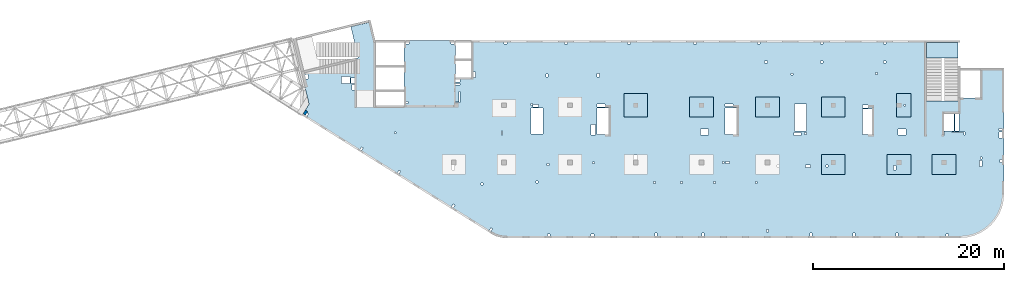
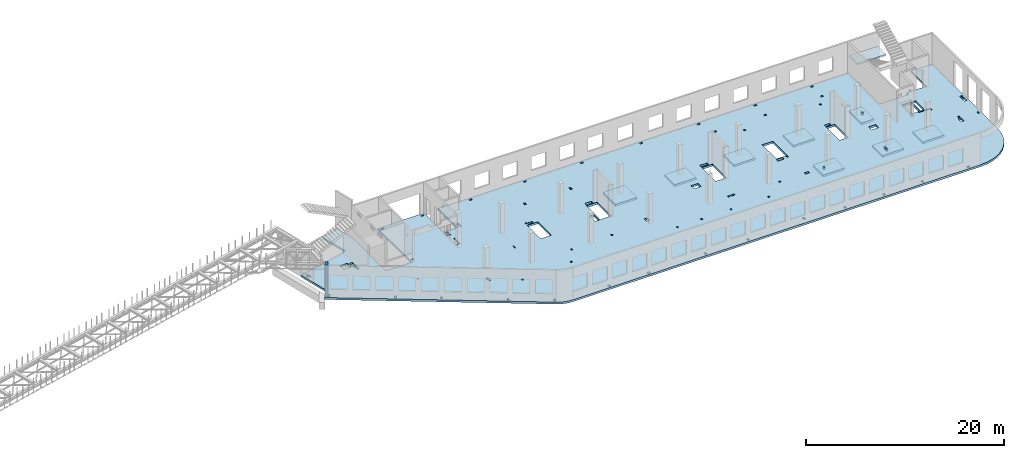
# One storey, part 14 of 67: 10 slabs, 1 wall.
"""IFC4 building model written with IfcOpenShell, lengths in millimetres."""

from ifc_helpers import new_model, entity, si_unit, converted_unit, derived_unit, direction, frame, origin, place, context, subcontext, project, spatial, indexed_curve, outline, extrude, material, type_object, element, save


model = new_model("IFC4")

# Units and contexts
model_context = context("Model", 3, precision=0.01, world=origin(), true_north=direction((6.12303176911189e-17, 1.0)))
plan_context = context("Plan", 3, precision=0.01, world=origin(), true_north=direction((6.12303176911189e-17, 1.0)))
body_context = subcontext(model_context, "Body", "Model", "MODEL_VIEW")
ifc_project = project(units=[si_unit("LENGTHUNIT", "METRE", prefix="MILLI"), si_unit("AREAUNIT", "SQUARE_METRE"), si_unit("VOLUMEUNIT", "CUBIC_METRE"), converted_unit("PLANEANGLEUNIT", "DEGREE", entity("IfcRatioMeasure", 0.0174532925199433), si_unit("PLANEANGLEUNIT", "RADIAN"), dimensions=[0, 0, 0, 0, 0, 0, 0]), si_unit("MASSUNIT", "GRAM", prefix="KILO"), derived_unit("MASSDENSITYUNIT", [(si_unit("MASSUNIT", "GRAM", prefix="KILO"), 1), (si_unit("LENGTHUNIT", "METRE"), -3)]), derived_unit("MOMENTOFINERTIAUNIT", [(si_unit("LENGTHUNIT", "METRE"), 4)]), si_unit("TIMEUNIT", "SECOND"), si_unit("FREQUENCYUNIT", "HERTZ"), si_unit("THERMODYNAMICTEMPERATUREUNIT", "DEGREE_CELSIUS"), derived_unit("THERMALTRANSMITTANCEUNIT", [(si_unit("MASSUNIT", "GRAM", prefix="KILO"), 1), (si_unit("THERMODYNAMICTEMPERATUREUNIT", "KELVIN"), -1), (si_unit("TIMEUNIT", "SECOND"), -3)]), derived_unit("VOLUMETRICFLOWRATEUNIT", [(si_unit("LENGTHUNIT", "METRE"), 3), (si_unit("TIMEUNIT", "SECOND"), -1)]), derived_unit("MASSFLOWRATEUNIT", [(si_unit("MASSUNIT", "GRAM", prefix="KILO"), 1), (si_unit("TIMEUNIT", "SECOND"), -1)]), derived_unit("ROTATIONALFREQUENCYUNIT", [(si_unit("TIMEUNIT", "SECOND"), -1)]), si_unit("ELECTRICCURRENTUNIT", "AMPERE"), si_unit("ELECTRICVOLTAGEUNIT", "VOLT"), si_unit("POWERUNIT", "WATT"), si_unit("FORCEUNIT", "NEWTON", prefix="KILO"), si_unit("ILLUMINANCEUNIT", "LUX"), si_unit("LUMINOUSFLUXUNIT", "LUMEN"), si_unit("LUMINOUSINTENSITYUNIT", "CANDELA"), derived_unit("USERDEFINED", [(si_unit("MASSUNIT", "GRAM", prefix="KILO"), -1), (si_unit("LENGTHUNIT", "METRE"), -2), (si_unit("TIMEUNIT", "SECOND"), 3), (si_unit("LUMINOUSFLUXUNIT", "LUMEN"), 1)]), derived_unit("LINEARVELOCITYUNIT", [(si_unit("LENGTHUNIT", "METRE"), 1), (si_unit("TIMEUNIT", "SECOND"), -1)]), si_unit("PRESSUREUNIT", "PASCAL"), derived_unit("USERDEFINED", [(si_unit("LENGTHUNIT", "METRE"), -2), (si_unit("MASSUNIT", "GRAM", prefix="KILO"), 1), (si_unit("TIMEUNIT", "SECOND"), -2)]), derived_unit("LINEARFORCEUNIT", [(si_unit("MASSUNIT", "GRAM", prefix="KILO"), 1), (si_unit("LENGTHUNIT", "METRE"), 1), (si_unit("TIMEUNIT", "SECOND"), -2), (si_unit("LENGTHUNIT", "METRE"), -1)]), derived_unit("PLANARFORCEUNIT", [(si_unit("MASSUNIT", "GRAM", prefix="KILO"), 1), (si_unit("LENGTHUNIT", "METRE"), 1), (si_unit("TIMEUNIT", "SECOND"), -2), (si_unit("LENGTHUNIT", "METRE"), -2)])], contexts=[model_context, plan_context])

# Site, building, storey
site_placement = place(None, origin())
site = spatial("IfcSite", under=ifc_project, at=site_placement, CompositionType="ELEMENT")
building_placement = place(site_placement, origin())
building = spatial("IfcBuilding", under=site, at=building_placement, CompositionType="ELEMENT")
storey_placement = place(building_placement, frame((0.0, 0.0, 19800.0)))
storey = spatial("IfcBuildingStorey", under=building, at=storey_placement, CompositionType="ELEMENT", Elevation=19800.0)

# Slabs
ifc_material = material()
slab_type_1 = type_object("IfcSlabType", PredefinedType="FLOOR", material=ifc_material)
slab_1_placement = place(storey_placement, origin())
element("IfcSlab", 1, at=slab_1_placement, inside=storey, type_object=slab_type_1, material=ifc_material, PredefinedType="FLOOR", context=body_context, shape_type="SweptSolid", body=[
    extrude(outline(indexed_curve([(-25035.3578436615, -19149.6834192696), (-1723.7807546778, -19149.6834192696), (-1545.14847241192, -19144.6936708545), (-1367.07327148811, -19129.7399866024), (-1190.11049593861, -19104.8690009648), (-1014.81202059395, -19070.1582764174), (-841.72453001009, -19025.7160615744), (-671.387813581896, -18971.6809536053), (-504.333082159904, -18908.2214660066), (-341.081311419952, -18835.5355030768), (-182.14161715224, -18753.8497427335), (-28.0096675365007, -18663.4189295977), (40258.2427502764, 6510.83324029911), (40838.4797487777, 6940.19687309205), (41344.4069782413, 7455.0433348891), (41763.5656731431, 8042.69563789314), (42085.6347553066, 8688.68383209804), (42302.6838150429, 9377.10154425057), (42409.3683841568, 10090.9976455501), (42403.0615344909, 10812.7936446974), (42283.9185616152, 11524.7165286898), (42054.8731609348, 12209.2363933869), (41721.5651903726, 12849.4980879286), (34742.4070907115, 24018.2161483196), (32622.301916857, 22693.3954199037), (34265.0803766703, 20064.4637935763), (32314.5829786219, 18845.6283246935), (32494.7586566307, 18557.2939267212), (29662.2972177258, 16787.3328545174), (26286.6526837235, 22189.3629466861), (-14169.2074788393, -3090.87446333766), (-12102.4862527243, -6398.23995847165), (-13480.5550665628, -7259.37371366059), (-15547.2762926778, -3952.0082185266), (-20126.7049663564, -6813.62192807755), (-16496.694769283, -12622.7123467952), (-19040.8218102156, -14212.4977409902), (-22670.832007289, -8403.40732227252), (-22712.6876077937, -8429.56223563854), (-24284.2776411098, -6895.90698258245), (-24423.9609210558, -7039.04531184302), (-24280.8225917953, -7178.7285917891), (-25628.7662432749, -8560.01346915358), (-23238.3778486726, -10892.7277685588), (-27547.6230145679, -15308.5133809195), (-25035.3846887576, -17760.1502337417), (-25035.3578436615, -19149.6834192696)], self_intersect=False), holes=[indexed_curve([(-22133.29936942, -13415.1223301469), (-22442.8348260668, -13608.5462197739), (-22760.7919049058, -13099.7208115874), (-22451.256448259, -12906.2969219603), (-22133.29936942, -13415.1223301469)], self_intersect=False), indexed_curve([(-21775.5976557261, -13987.5509143567), (-21987.6082424705, -14120.0330305396), (-22284.3681827202, -13645.1293162322), (-22072.3575959758, -13512.6472000493), (-21775.5976557261, -13987.5509143567)], self_intersect=False), indexed_curve([(-11722.1849951182, -9261.85584637686), (-12086.8432043185, -9489.72508621147), (-12129.2374814971, -9421.88169845327), (-11832.4226600549, -9236.40673579719), (-12415.3439712598, -8303.56015412191), (-12347.5005835016, -8261.16587694338), (-11722.1849951182, -9261.85584637686)], self_intersect=False), indexed_curve([(-13242.0872574336, -7640.99276980047), (-13374.5693736165, -7428.98218305609), (-13009.9111644161, -7201.11294322148), (-12877.4290482332, -7413.12352996586), (-13242.0872574336, -7640.99276980047)], self_intersect=False), indexed_curve([(-5628.70693935832, -1916.57657305384), (-5459.09846996282, -1810.5908801075), (-5289.52136124868, -2081.96443114031), (-5459.12983064419, -2187.95012408664), (-5628.70693935832, -1916.57657305384)], self_intersect=False), indexed_curve([(34805.8880217444, 16198.6065676781), (34986.0636997531, 15910.2721697058), (34918.2203119949, 15867.8778925273), (34780.4389111647, 16088.3689027414), (33677.9838600939, 15399.4618985902), (33635.5895829154, 15467.3052863485), (34805.8880217444, 16198.6065676781)], self_intersect=False), indexed_curve([(37927.9797280557, 14617.8898262316), (38251.236091542, 14100.5839945753), (37988.3429639789, 13936.3061705085), (37665.0866004926, 14453.6120021647), (37927.9797280557, 14617.8898262316)], self_intersect=False), indexed_curve([(-1135.1376532047, 950.344261314779), (-940.08791339986, 1072.22780820307), (-749.313666096461, 766.932563291155), (-944.363405901299, 645.04901640287), (-1135.1376532047, 950.344261314779)], self_intersect=False), indexed_curve([(16089.6652817492, 11749.2314200073), (16259.2737511447, 11855.2171129536), (16365.259444091, 11685.6086435581), (16195.6509746955, 11579.6229506118), (16089.6652817492, 11749.2314200073)], self_intersect=False), indexed_curve([(23569.4069610802, 16517.5397477249), (23739.0154304757, 16623.5254406713), (23845.001123422, 16453.9169712758), (23675.3926540265, 16347.9312783294), (23569.4069610802, 16517.5397477249)], self_intersect=False), indexed_curve([(-4628.33119641944, -5064.85428712623), (-4495.84908023653, -5276.86487387061), (-4970.75279454395, -5573.62481412034), (-5103.23491072686, -5361.61422737596), (-4628.33119641944, -5064.85428712623)], self_intersect=False), indexed_curve([(-4030.49662256684, -5115.78386896694), (-2594.39048314403, -7413.97862927603), (-3662.92384033572, -8081.68849483792), (-5099.02997975852, -5783.49373452883), (-4030.49662256684, -5115.78386896694)], self_intersect=False), indexed_curve([(1253.91022629488, -1306.59011826816), (1423.48733500901, -1577.96366930096), (728.092610487371, -2012.50501038096), (558.515501773239, -1741.13145934816), (1253.91022629488, -1306.59011826816)], self_intersect=False), indexed_curve([(1843.25645725139, -1457.15866891798), (3313.80794688175, -3810.4761817806), (2245.27458969007, -4478.18604734249), (774.723100059713, -2124.86853447986), (1843.25645725139, -1457.15866891798)], self_intersect=False), indexed_curve([(1740.68547315327, -4840.66338935521), (1163.06344659577, -3916.29723114972), (1553.16292620543, -3672.53013737315), (2130.78495276294, -4596.89629557865), (1740.68547315327, -4840.66338935521)], self_intersect=False), indexed_curve([(11463.4910605066, 1234.9663319602), (11145.5339816676, 1743.79174014671), (11849.4091296589, 2183.63236587399), (12167.3662084979, 1674.80695768748), (11463.4910605066, 1234.9663319602)], self_intersect=False), indexed_curve([(14896.1975903923, 72.3933752474018), (15065.8060597878, 178.379068193729), (15171.7917527341, 8.77059879822273), (15002.1832833386, -97.2150941481066), (14896.1975903923, 72.3933752474018)], self_intersect=False), indexed_curve([(12634.6385227333, 5805.04987843064), (12788.3177775055, 5559.11759780716), (12059.0013591048, 5103.37911813794), (11905.3221043326, 5349.31139876142), (12634.6385227333, 5805.04987843064)], self_intersect=False), indexed_curve([(13207.0239067502, 5643.88275848624), (14677.5753963806, 3290.56524562361), (13609.0420391889, 2622.85538006173), (12138.4905495585, 4976.17289292435), (13207.0239067502, 5643.88275848624)], self_intersect=False), indexed_curve([(19150.2533898443, 9870.66027583487), (20665.8487989769, 7445.25916347915), (19597.3154417852, 6777.54929791726), (18081.7200326527, 9202.95041027297), (19150.2533898443, 9870.66027583487)], self_intersect=False), indexed_curve([(20240.2252958214, 7031.8953605626), (20399.2038352409, 6777.48265646934), (19780.1329219473, 6390.63487721523), (19621.1543825278, 6645.04758130849), (20240.2252958214, 7031.8953605626)], self_intersect=False), indexed_curve([(25270.9461080048, 13058.6252458208), (26685.8551088383, 10794.3521793908), (25837.8127618608, 10264.4237146591), (24422.9037610273, 12528.6967810891), (25270.9461080048, 13058.6252458208)], self_intersect=False), indexed_curve([(28111.3878345621, 15193.224926799), (27941.7793651666, 15087.2392338527), (27835.7936722203, 15256.8477032482), (28005.4021416158, 15362.8333961945), (28111.3878345621, 15193.224926799)], self_intersect=False), indexed_curve([(29412.3642136373, 13158.4498458438), (29730.3212924763, 12649.6244376573), (29115.4924335878, 12265.4274521827), (29017.9675636854, 12204.4856787385), (28700.0104848464, 12713.3110869251), (28797.5335120786, 12774.2517089133), (29412.3642136373, 13158.4498458438)], self_intersect=False), indexed_curve([(23022.5065390695, 4466.46925882629), (22598.4853655807, 4201.50502646046), (22466.0032493978, 4413.51561320483), (22890.0244228865, 4678.47984557067), (23022.5065390695, 4466.46925882629)], self_intersect=False), indexed_curve([(-10781.317628673, -1445.50910142009), (-11035.7303327662, -1604.48764083959), (-11141.7160257126, -1434.87917144409), (-10887.3033216193, -1275.90063202459), (-10781.317628673, -1445.50910142009)], self_intersect=False), indexed_curve([(-5396.2487253657, 1919.53664962593), (-5650.66142945896, 1760.55811020644), (-5756.64712240529, 1930.16657960194), (-5502.23441831203, 2089.14511902144), (-5396.2487253657, 1919.53664962593)], self_intersect=False), indexed_curve([(-19490.7125321322, -6887.87443421422), (-19745.1252362254, -7046.85297363371), (-19851.1109291718, -6877.24450423821), (-19596.6982250785, -6718.26596481871), (-19490.7125321322, -6887.87443421422)], self_intersect=False), indexed_curve([(200.830764685962, 5417.06451685487), (-53.5819394072999, 5258.08597743537), (-159.567632353634, 5427.69444683087), (94.8450717396271, 5586.67298625037), (200.830764685962, 5417.06451685487)], self_intersect=False), indexed_curve([(6052.32295883088, 9073.57092350331), (5797.91025473762, 8914.59238408381), (5691.92456179129, 9084.20085347932), (5946.33726588455, 9243.17939289881), (6052.32295883088, 9073.57092350331)], self_intersect=False), indexed_curve([(11734.2066835803, 12624.0916372054), (11479.793979487, 12465.1130977859), (11373.8082865407, 12634.7215671814), (11628.220990634, 12793.7001066009), (11734.2066835803, 12624.0916372054)], self_intersect=False), indexed_curve([(17331.286173632, 16121.6195044343), (17076.8734695387, 15962.6409650148), (16970.8877765924, 16132.2494344104), (17225.3004806856, 16291.2279738298), (17331.286173632, 16121.6195044343)], self_intersect=False), indexed_curve([(22928.3656636836, 19619.1473716633), (22673.9529595903, 19460.1688322438), (22567.967266644, 19629.7773016393), (22822.3799707373, 19788.7558410588), (22928.3656636836, 19619.1473716633)], self_intersect=False), indexed_curve([(23977.6240238523, 17940.0235246478), (23723.211319759, 17781.0449852283), (23617.2256268127, 17950.6534546238), (23871.6383309059, 18109.6319940433), (23977.6240238523, 17940.0235246478)], self_intersect=False), indexed_curve([(18380.5445338006, 14442.4956574189), (18126.1318297074, 14283.5171179994), (18020.1461367611, 14453.1255873949), (18274.5588408543, 14612.1041268144), (18380.5445338006, 14442.4956574189)], self_intersect=False), indexed_curve([(13419.4968039821, 11342.4141387387), (13165.0840998889, 11183.4355993192), (13059.0984069425, 11353.0440687147), (13313.5111110358, 11512.0226081342), (13419.4968039821, 11342.4141387387)], self_intersect=False), indexed_curve([(-22943.636825664, -13042.9957293671), (-22551.4897617626, -13670.5470661305), (-23314.7278740424, -14147.482684389), (-23706.8749379438, -13519.9313476256), (-22943.636825664, -13042.9957293671)], self_intersect=False), indexed_curve([(-26693.9639157555, -15722.3725280137), (-27051.8095806284, -15373.1644826066), (-26842.2848799564, -15158.457213386), (-26484.4419576682, -15507.6680692153), (-26693.9639157555, -15722.3725280137)], self_intersect=False), indexed_curve([(-24735.3672304539, -18649.9890495262), (-24535.3672304924, -18649.9851256142), (-24535.3613446244, -18949.9851255565), (-24735.3613445859, -18949.9890494685), (-24735.3672304539, -18649.9890495262)], self_intersect=False), indexed_curve([(-17995.3672317511, -18649.8568136923), (-17795.3672317896, -18649.8528897804), (-17795.3613459216, -18949.8528897226), (-17995.3613458831, -18949.8568136346), (-17995.3672317511, -18649.8568136923)], self_intersect=False), indexed_curve([(-13365.3672326422, -18649.7659751299), (-13165.3672326807, -18649.7620512179), (-13165.3613468127, -18949.7620511602), (-13365.3613467742, -18949.7659750722), (-13365.3672326422, -18649.7659751299)], self_intersect=False), indexed_curve([(-6665.36723393173, -18649.6345240786), (-6465.36723397022, -18649.6306001666), (-6465.36134810225, -18949.6306001088), (-6665.36134806376, -18949.6345240208), (-6665.36723393173, -18649.6345240786)], self_intersect=False), indexed_curve([(-1995.36723483054, -18649.5429007335), (-1795.36723486903, -18649.5389768216), (-1795.36134900105, -18949.5389767638), (-1995.36134896257, -18949.5429006758), (-1995.36723483054, -18649.5429007335)], self_intersect=False), indexed_curve([(-15760.2274862019, -15405.2679960053), (-15680.7382164921, -15532.4743480519), (-15807.9445685388, -15611.9636177617), (-15887.4338382485, -15484.7572657151), (-15760.2274862019, -15405.2679960053)], self_intersect=False), indexed_curve([(-16289.959946675, -12198.7303741582), (-16459.5684160705, -12304.7160671045), (-16565.5541090168, -12135.107597709), (-16395.9456396213, -12029.1219047627), (-16289.959946675, -12198.7303741582)], self_intersect=False), indexed_curve([(-5197.32627309738, -15136.9063702166), (-5091.34058015106, -15306.5148396121), (-5260.94904954656, -15412.5005325584), (-5366.93474249289, -15242.8920631629), (-5197.32627309738, -15136.9063702166)], self_intersect=False), indexed_curve([(-6114.83658600321, -9743.560306838), (-6199.64082070096, -9796.55315331116), (-6411.61220659362, -9457.33621452015), (-6326.80797189587, -9404.34336804699), (-6114.83658600321, -9743.560306838)], self_intersect=False), indexed_curve([(3605.89099011392, -15920.9764032486), (3711.87668306025, -16090.5848726441), (3457.463978967, -16249.5634120636), (3351.47828602067, -16079.9549426681), (3605.89099011392, -15920.9764032486)], self_intersect=False), indexed_curve([(7489.92493927099, -13493.9040347776), (7595.91063221732, -13663.5125041731), (7341.49792812406, -13822.4910435926), (7235.51223517773, -13652.8825741971), (7489.92493927099, -13493.9040347776)], self_intersect=False), indexed_curve([(-394.20584995626, -11887.8820242313), (-288.220157009933, -12057.4904936268), (-457.828626405432, -12163.4761865732), (-563.814319351763, -11993.8677171777), (-394.20584995626, -11887.8820242313)], self_intersect=False), indexed_curve([(-431.124438654749, -9705.87331256026), (-325.138745708416, -9875.48178195576), (-494.747215103917, -9981.4674749021), (-600.73290805025, -9811.85900550659), (-431.124438654749, -9705.87331256026)], self_intersect=False), indexed_curve([(-5353.39564282971, -5376.43340797962), (-5200.74802037376, -5281.04628432792), (-5094.76232742743, -5450.65475372343), (-5247.40994988338, -5546.04187737513), (-5353.39564282971, -5376.43340797962)], self_intersect=False), indexed_curve([(3535.0797832171, -7032.88826389166), (3641.06547616344, -7202.49673328717), (3471.45700676793, -7308.4824262335), (3365.4713138216, -7138.873956838), (3535.0797832171, -7032.88826389166)], self_intersect=False), indexed_curve([(-13069.8605063958, -7916.60653256817), (-13149.3497761055, -7789.40018052154), (-12784.6915669052, -7561.53094068692), (-12705.2022971954, -7688.73729273355), (-13069.8605063958, -7916.60653256817)], self_intersect=False), indexed_curve([(12872.8835369238, -10012.2583411499), (13042.4920063193, -9906.27264820362), (13201.4705457388, -10160.6853522969), (13031.8620763433, -10266.6710452432), (12872.8835369238, -10012.2583411499)], self_intersect=False), indexed_curve([(17070.6931544625, -7389.11244072825), (17240.301623858, -7283.12674778192), (17399.2801632775, -7537.53945187517), (17229.671693882, -7643.5251448215), (17070.6931544625, -7389.11244072825)], self_intersect=False), indexed_curve([(10078.5817186322, -5408.45531014478), (10184.5674115785, -5578.06377954029), (10014.958942183, -5684.04947248662), (9908.97324923671, -5514.44100309111), (10078.5817186322, -5408.45531014478)], self_intersect=False), indexed_curve([(12461.5807136391, -3919.35632424882), (12567.5664065854, -4088.96479364433), (12397.9579371899, -4194.95048659066), (12291.9722442436, -4025.34201719516), (12461.5807136391, -3919.35632424882)], self_intersect=False), indexed_curve([(15378.8463872417, -2096.40240557192), (15484.8320801881, -2266.01087496742), (15315.2236107926, -2371.99656791375), (15209.2379178463, -2202.38809851824), (15378.8463872417, -2096.40240557192)], self_intersect=False), indexed_curve([(19101.7522904731, 229.983554600057), (19207.7379834194, 60.3750852045558), (19038.1295140239, -45.6106077417833), (18932.1438210776, 123.99786165372), (19101.7522904731, 229.983554600057)], self_intersect=False), indexed_curve([(22566.0467637286, -3483.47693429318), (22735.6552331241, -3377.49124134686), (22894.6337725436, -3631.90394544011), (22725.0253031481, -3737.88963838644), (22566.0467637286, -3483.47693429318)], self_intersect=False), indexed_curve([(15193.0124118344, 257.868337903477), (15549.190197565, 480.43829309077), (15655.1758905113, 310.829823695274), (15298.9981047808, 88.2598685079719), (15193.0124118344, 257.868337903477)], self_intersect=False), indexed_curve([(20835.425907691, 7173.88561244634), (20665.8174382955, 7067.89991950001), (20559.8317453492, 7237.50838889551), (20729.4402147447, 7343.49408184184), (20835.425907691, 7173.88561244634)], self_intersect=False), indexed_curve([(26645.0912518388, -1406.22007390789), (26814.6997212343, -1300.23438096156), (26973.6782606538, -1554.64708505483), (26804.0697912583, -1660.63277800115), (26645.0912518388, -1406.22007390789)], self_intersect=False), indexed_curve([(30469.7622367074, 983.757302031897), (30639.3707061029, 1089.74299497822), (30798.3492455224, 835.330290884961), (30628.7407761269, 729.344597938634), (30469.7622367074, 983.757302031897)], self_intersect=False), indexed_curve([(34294.4332215761, 3373.73467797166), (34464.0416909716, 3479.72037091801), (34623.0202303911, 3225.30766682474), (34453.4117609956, 3119.3219738784), (34294.4332215761, 3373.73467797166)], self_intersect=False), indexed_curve([(24359.3123452595, 12630.4618627264), (24208.282732811, 12872.153931615), (24717.1081409975, 13190.111010454), (24868.137753446, 12948.4189415654), (24359.3123452595, 12630.4618627264)], self_intersect=False), indexed_curve([(38774.2071192719, 6055.15702917322), (39028.6198233651, 6214.13556859271), (39134.6055163114, 6044.52709919721), (38880.1928122182, 5885.54855977772), (38774.2071192719, 6055.15702917322)], self_intersect=False), indexed_curve([(37832.592604404, 14770.5374486875), (37662.9841350085, 14664.5517557412), (37556.9984420621, 14834.1602251367), (37726.6069114576, 14940.145918083), (37832.592604404, 14770.5374486875)], self_intersect=False), indexed_curve([(39633.5850115564, 15436.066880475), (39474.6064721369, 15690.4795845682), (39644.2142479431, 15796.4648441014), (39803.1927873626, 15542.0521400081), (39633.5850115564, 15436.066880475)], self_intersect=False), indexed_curve([(37667.5340334719, 18393.6239323588), (37921.9474311545, 18552.6029051915), (38027.9331241009, 18382.994435796), (37773.5197264183, 18224.0154629633), (37667.5340334719, 18393.6239323588)], self_intersect=False), indexed_curve([(37860.957923099, 18084.088475712), (38115.3713207816, 18243.0674485447), (38433.3283996206, 17734.2420403582), (38178.915001938, 17575.2630675255), (37860.957923099, 18084.088475712)], self_intersect=False), indexed_curve([(33008.038246152, 15075.158222447), (33188.2139241608, 14786.8238244747), (33120.3705364026, 14744.4295472962), (32940.1948583938, 15032.7639452685), (33008.038246152, 15075.158222447)], self_intersect=False), indexed_curve([(32802.046604642, 17216.3710665211), (33758.5674834826, 15685.6546302267), (32876.603442626, 15134.5290269058), (31920.0825637853, 16665.2454632002), (32802.046604642, 17216.3710665211)], self_intersect=False), indexed_curve([(33234.5482016005, 17486.6345835343), (34191.0690804411, 15955.9181472398), (33860.3325651199, 15749.2460459945), (32903.8116862793, 17279.9624822889), (33183.6656607819, 17454.8388756504), (33234.5482016005, 17486.6345835343)], self_intersect=False), indexed_curve([(-8724.99463551253, -15077.252738595), (-8428.2346952628, -15552.1564529024), (-8640.24528200717, -15684.6385690853), (-8937.0052222569, -15209.7348547779), (-8724.99463551253, -15077.252738595)], self_intersect=False), indexed_curve([(7203.41403081956, -4487.07820658831), (6923.56005631698, -4661.95459994976), (6642.6979700092, -4212.49215605167), (6922.55194451179, -4037.61576269022), (7203.41403081956, -4487.07820658831)], self_intersect=False), indexed_curve([(20197.470370807, 2760.1074425607), (20027.8619014115, 2654.12174961437), (19921.8762084652, 2823.73021900988), (20091.4846778607, 2929.7159119562), (20197.470370807, 2760.1074425607)], self_intersect=False), indexed_curve([(24577.608729869, 5497.18854393024), (24408.0002604735, 5391.20285098393), (24302.0145675272, 5560.81132037942), (24471.6230369227, 5666.79701332575), (24577.608729869, 5497.18854393024)], self_intersect=False), indexed_curve([(30785.2437920549, 8951.73517525887), (30573.2332053105, 8819.25305907597), (30308.2689729447, 9243.27423256473), (30520.2795596891, 9375.75634874763), (30785.2437920549, 8951.73517525887)], self_intersect=False), indexed_curve([(-15504.9135013378, -4397.21064997542), (-15759.326205431, -4556.18918939492), (-15865.3118983774, -4386.58071999942), (-15610.8991942841, -4227.60218057992), (-15504.9135013378, -4397.21064997542)], self_intersect=False), indexed_curve([(-12229.6379372401, -5817.35020929626), (-12017.6273504957, -5684.86809311334), (-11720.8674102459, -6159.77180742076), (-11932.8779969903, -6292.25392360367), (-12229.6379372401, -5817.35020929626)], self_intersect=False)]), frame((31379.0305927559, 15612.5256979213, -400.0), z_axis=(0.0, 0.0, 1.0), x_axis=(0.848042346977523, -0.52992846473166, 0.0)), (0.0, 0.0, 1.0), 249.999999999999),
])
slab_type_2 = type_object("IfcSlabType", PredefinedType="FLOOR", material=ifc_material)
slab_2_placement = place(storey_placement, origin())
element("IfcSlab", 2, at=slab_2_placement, inside=storey, type_object=slab_type_2, material=ifc_material, PredefinedType="FLOOR", context=body_context, shape_type="SweptSolid", body=[
    extrude(outline(indexed_curve([(-1249.99990844727, -1049.99999999999), (1249.99990844727, -1049.99999999999), (1249.99990844727, 1049.99999999999), (-1249.99990844727, 1049.99999999999), (-1249.99990844727, -1049.99999999999)], self_intersect=False), holes=[indexed_curve([(534.999908447283, 49.999314856667), (534.999908447283, 249.999314856666), (734.999908447263, 249.999314856666), (734.999908447263, 49.999314856667), (534.999908447283, 49.999314856667)], self_intersect=False)]), frame((55670.0001770019, 7499.99922635556, -650.0), z_axis=(0.0, 0.0, 1.0), x_axis=(-1.0, 0.0, 0.0)), (0.0, 0.0, 1.0), 249.999999999999),
])
slab_type_3 = type_object("IfcSlabType", PredefinedType="FLOOR", material=ifc_material)
slab_3_placement = place(storey_placement, origin())
element("IfcSlab", 3, at=slab_3_placement, inside=storey, type_object=slab_type_3, material=ifc_material, PredefinedType="FLOOR", context=body_context, shape_type="SweptSolid", body=[
    extrude(outline(indexed_curve([(-1249.99999999999, -1050.0), (1250.00000000001, -1050.0), (1250.00000000001, 1050.0), (-1249.99999999999, 1050.0), (-1249.99999999999, -1050.0)], self_intersect=False), holes=[indexed_curve([(340.000000000009, 110.000000000013), (340.000000000009, 610.000000000013), (590.000000000004, 610.000000000013), (590.000000000004, 110.000000000013), (340.000000000009, 110.000000000013)], self_intersect=False)]), frame((62570.0002685547, 7499.99922635553, -650.0), z_axis=(0.0, 0.0, 1.0), x_axis=(-1.0, 0.0, 0.0)), (0.0, 0.0, 1.0), 249.999999999999),
])
slab_type_4 = type_object("IfcSlabType", PredefinedType="FLOOR", material=ifc_material)
slab_4_placement = place(storey_placement, origin())
element("IfcSlab", 4, at=slab_4_placement, inside=storey, type_object=slab_type_4, material=ifc_material, PredefinedType="FLOOR", context=body_context, shape_type="SweptSolid", body=[
    extrude(outline(indexed_curve([(-1050.0, -1249.99999999999), (1050.0, -1249.99999999999), (1050.0, 1250.00000000001), (-1050.0, 1250.00000000001), (-1050.0, -1249.99999999999)], self_intersect=False)), frame((67280.0002685547, 7499.99922635549, -400.0), z_axis=(0.0, 0.0, -1.0), x_axis=(0.0, 1.0, 0.0)), (0.0, 0.0, 1.0), 249.999999999999),
])
slab_type_5 = type_object("IfcSlabType", PredefinedType="FLOOR", material=ifc_material)
slab_5_placement = place(storey_placement, origin())
element("IfcSlab", 5, at=slab_5_placement, inside=storey, type_object=slab_type_5, material=ifc_material, PredefinedType="FLOOR", context=body_context, shape_type="SweptSolid", body=[
    extrude(outline(indexed_curve([(-1250.0, -1250.0), (1250.0, -1250.0), (1250.0, 1250.0), (-1250.0, 1250.0), (-1250.0, -1250.0)], self_intersect=False)), frame((34970.0002685547, 13699.9992263557, -400.0), z_axis=(0.0, 0.0, -1.0), x_axis=(0.0, 1.0, 0.0)), (0.0, 0.0, 1.0), 249.999999999999),
])
slab_type_6 = type_object("IfcSlabType", PredefinedType="FLOOR", material=ifc_material)
slab_6_placement = place(storey_placement, origin())
element("IfcSlab", 6, at=slab_6_placement, inside=storey, type_object=slab_type_6, material=ifc_material, PredefinedType="FLOOR", context=body_context, shape_type="SweptSolid", body=[
    extrude(outline(indexed_curve([(-1049.99999999999, -1250.0), (1049.99999999999, -1250.0), (1049.99999999999, 1249.99999999999), (-1049.99999999999, 1249.99999999999), (-1049.99999999999, -1250.0)], self_intersect=False)), frame((41870.0002685547, 13499.9992263557, -400.0), z_axis=(0.0, 0.0, -1.0), x_axis=(0.0, 1.0, 0.0)), (0.0, 0.0, 1.0), 249.999999999999),
])
slab_type_7 = type_object("IfcSlabType", PredefinedType="FLOOR", material=ifc_material)
slab_7_placement = place(storey_placement, origin())
element("IfcSlab", 7, at=slab_7_placement, inside=storey, type_object=slab_type_7, material=ifc_material, PredefinedType="FLOOR", context=body_context, shape_type="SweptSolid", body=[
    extrude(outline(indexed_curve([(-1049.99999999999, -1249.99990844726), (1049.99999999999, -1249.99990844726), (1049.99999999999, 1249.99990844727), (-1049.99999999999, 1249.99990844727), (-1049.99999999999, -1249.99990844726)], self_intersect=False)), frame((55670.000177002, 13499.9992263556, -400.0), z_axis=(0.0, 0.0, -1.0), x_axis=(0.0, 1.0, 0.0)), (0.0, 0.0, 1.0), 249.999999999999),
])
slab_type_8 = type_object("IfcSlabType", PredefinedType="FLOOR", material=ifc_material)
slab_8_placement = place(storey_placement, origin())
element("IfcSlab", 8, at=slab_8_placement, inside=storey, type_object=slab_type_8, material=ifc_material, PredefinedType="FLOOR", context=body_context, shape_type="SweptSolid", body=[
    extrude(outline(indexed_curve([(-1000.00000000001, -1250.0), (500.000000000008, -1250.0), (500.000000000008, -250.00000000001), (500.000000000008, 249.999999999989), (500.000000000008, 1250.0), (-1000.00000000001, 1250.0), (-1000.00000000001, -1250.0)], self_intersect=False), holes=[indexed_curve([(-449.999999999993, -100.000000000005), (-449.999999999993, 99.9999999999946), (-250.000000000004, 99.9999999999946), (-250.000000000004, -100.000000000005), (-449.999999999993, -100.000000000005)], self_intersect=False)]), frame((62820.0002685547, 13699.9992263555, -650.0), z_axis=(0.0, 0.0, 1.0), x_axis=(-1.0, 0.0, 0.0)), (0.0, 0.0, 1.0), 249.999999999999),
])
slab_type_9 = type_object("IfcSlabType", PredefinedType="FLOOR", material=ifc_material)
slab_9_placement = place(storey_placement, origin())
element("IfcSlab", 9, at=slab_9_placement, inside=storey, type_object=slab_type_9, material=ifc_material, PredefinedType="FLOOR", context=body_context, shape_type="SweptSolid", body=[
    extrude(outline(indexed_curve([(-1049.99999999999, -1249.99999999999), (1049.99999999999, -1249.99999999999), (1049.99999999999, 1250.0), (-1049.99999999999, 1250.0), (-1049.99999999999, -1249.99999999999)], self_intersect=False)), frame((48770.0002685547, 13499.9992263556, -400.0), z_axis=(0.0, 0.0, -1.0), x_axis=(0.0, 1.0, 0.0)), (0.0, 0.0, 1.0), 249.999999999999),
])
slab_type_10 = type_object("IfcSlabType", PredefinedType="FLOOR", material=ifc_material)
slab_10_placement = place(storey_placement, origin())
element("IfcSlab", 10, at=slab_10_placement, inside=storey, type_object=slab_type_10, material=ifc_material, PredefinedType="FLOOR", context=body_context, shape_type="SweptSolid", body=[
    extrude(outline(indexed_curve([(-834.999999999999, -1670.00000000001), (835.000000000001, -1670.00000000001), (835.000000000001, 1670.00000000002), (-834.999999999999, 1670.00000000002), (-834.999999999999, -1670.00000000001)], self_intersect=False)), frame((67100.0002685547, 19464.999226356, 2070.0), z_axis=(0.0, 0.0, -1.0), x_axis=(0.0, 1.0, 0.0)), (0.0, 0.0, 1.0), 199.999999999998),
])

# Wall
wall_type = type_object("IfcWallType", PredefinedType="STANDARD")
wall_placement = place(storey_placement, frame((233.050189522876, 12729.5913450927, -150.0), z_axis=(0.0, 0.0, 1.0), x_axis=(0.529911826412026, 0.848052743777574, 0.0)))
element("IfcWall", 11, at=wall_placement, inside=storey, type_object=wall_type, material=ifc_material, PredefinedType="NOTDEFINED", context=body_context, shape_type="SweptSolid", body=[
    extrude(outline(indexed_curve([(450.000000000002, 150.0), (-6.93711754706783e-13, 150.0), (6.85251855259139e-13, -150.0), (450.000000000004, -150.0), (450.000000000002, 150.0)], self_intersect=False)), origin(), (0.0, 0.0, 1.0), 3950.0),
])

save(model, "model.ifc")
